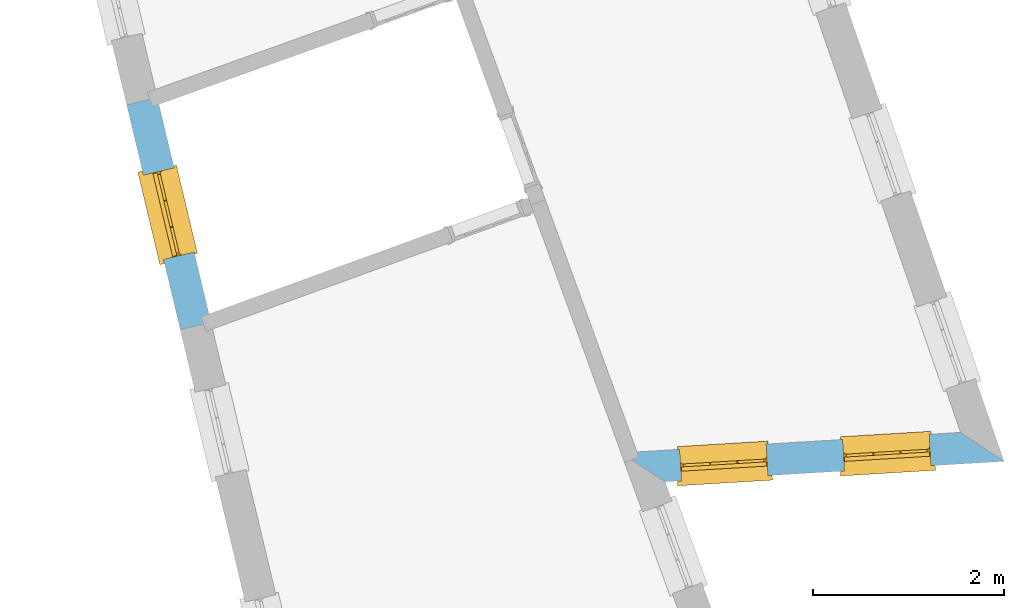
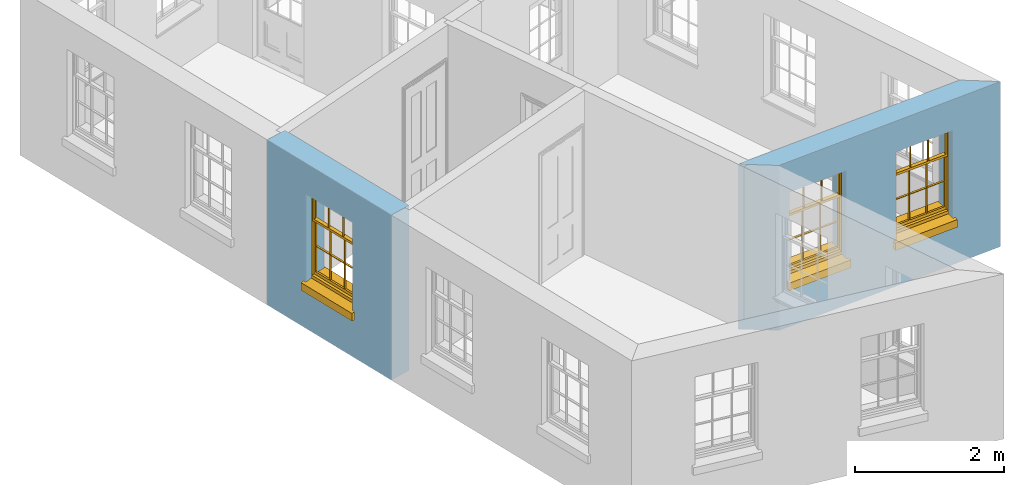
# One storey, part 5 of 12: 3 windows, 3 openings, plus 2 elements that do not belong to this part.
"""IFC2X3 building model written with IfcOpenShell, lengths in metres."""

from ifc_helpers import new_model, si_unit, frame, origin, place, context, subcontext, project, spatial, polyline, outline, extrude, faceted_brep, material, layer, layer_set, layer_usage, element, fill, save


model = new_model("IFC2X3")

# Units and contexts
model_context = context("Model", 3, world=origin())
body_context = subcontext(model_context, "Body", "Model", "MODEL_VIEW")
ifc_project = project(units=[si_unit("PLANEANGLEUNIT", "RADIAN"), si_unit("MASSUNIT", "GRAM", prefix="KILO"), si_unit("FORCEUNIT", "NEWTON", prefix="KILO"), si_unit("LENGTHUNIT", "METRE")], contexts=[model_context])

# Site, building, storey
site_placement = place(None, origin())
site = spatial("IfcSite", under=ifc_project, at=site_placement, CompositionType="ELEMENT")
building_placement = place(None, origin())
building = spatial("IfcBuilding", under=site, at=building_placement, Name="Building plot-12", CompositionType="ELEMENT")
storey_placement = place(None, frame((0.0, 0.0, 6.45)))
storey = spatial("IfcBuildingStorey", under=building, at=storey_placement, Name="Floor 1", CompositionType="ELEMENT", Elevation=6.45)

# Wall, openings, windows
ifc_material = material(Name="Masonry")
ifc_layer = layer(ifc_material, 0.33, ventilated=False)
ifc_layer_set = layer_set([ifc_layer], Name="My Wall")
ifc_layer_usage = layer_usage(ifc_layer_set, "AXIS2", "NEGATIVE", 0.08)
wall_1_placement = place(storey_placement, origin())
wall_1 = element("IfcWallStandardCase", 1, at=wall_1_placement, inside=storey, material=ifc_layer_usage, Name="exterior", context=body_context, shape_type="SweptSolid", body=[
    extrude(outline(polyline([(59.0480704661197, 34.8587662516055), (59.5092760501621, 34.5560013261806), (63.057647216937, 34.7701593682112), (62.6036094343713, 35.0733568984167), (59.0480704661197, 34.8587662516055)])), origin(), (0.0, 0.0, 1.0), 2.7),
])
opening_1_placement = place(storey_placement, frame((0.0, 0.0, 0.75)))
opening_1 = element("IfcOpeningElement", 2, at=opening_1_placement, cuts=wall_1, Name="Opening", ObjectType="Opening", context=body_context, shape_type="SweptSolid", body=[
    extrude(outline(polyline([(59.6792223070511, 34.5662582457403), (60.5875694412412, 34.6210805387303), (60.5676888294976, 34.9504811478322), (59.6593416953075, 34.8956588548422), (59.6792223070511, 34.5662582457403)])), origin(), (0.0, 0.0, 1.0), 1.445),
])
opening_2_placement = place(storey_placement, frame((0.0, 0.0, 0.75)))
opening_2 = element("IfcOpeningElement", 3, at=opening_2_placement, cuts=wall_1, Name="Opening", ObjectType="Opening", context=body_context, shape_type="SweptSolid", body=[
    extrude(outline(polyline([(61.3861163723973, 34.6692759611392), (62.2944635065874, 34.7240982541292), (62.2745828948438, 35.0534988632311), (61.3662357606537, 34.9986765702411), (61.3861163723973, 34.6692759611392)])), origin(), (0.0, 0.0, 1.0), 1.445),
])
window_1_placement = place(storey_placement, frame((59.6641612375484, 34.8158041617266, 0.75), z_axis=(0.0, 0.0, 1.0), x_axis=(0.908347134190073, 0.0548222929900248, 0.0)))
window_1 = element("IfcWindow", 4, at=window_1_placement, inside=storey, Name="bedroom outside window", OverallHeight=1.445, OverallWidth=0.91, context=body_context, shape_type="Brep", held_by="IfcProductRepresentation", body=[
    faceted_brep([(0.876875, -0.105, 0.999097), (0.876875, -0.105, 1.411875), (0.9, -0.105, 1.435), (0.033125, -0.105, 1.411875), (0.033125, -0.105, 0.999097), (0.01, -0.105, 1.435), (0.033125, -0.135, 1.411875), (0.01, -0.135, 1.435), (0.033125, -0.135, 0.999097), (0.876875, -0.135, 1.411875), (0.876875, -0.135, 0.999097), (0.9, -0.135, 1.435), (0.033125, -0.105, 0.960972), (0.01, -0.105, 0.960972), (0.033125, -0.105, 0.548195), (0.876875, -0.105, 0.960972), (0.876875, -0.105, 0.548195), (0.9, -0.105, 0.960972), (0.876875, -0.105, 0.538195), (0.876875, -0.105, 0.125417), (0.9, -0.105, 0.077167), (0.033125, -0.105, 0.125417), (0.033125, -0.105, 0.538195), (0.01, -0.105, 0.077167), (0.9, -0.135, 0.960972), (0.01, -0.135, 0.960972), (-0.0425, -0.25, 0.01), (-0.0425, -0.3, 0.001667), (0.0, -0.25, 0.01), (0.9525, -0.25, 0.01), (0.91, -0.25, 0.01), (0.9525, -0.3, 0.001667), (-0.02, 0.08, 0.077167), (0.0, 0.08, 0.077167), (-0.02, 0.11, 0.077167), (0.0, -0.06, 0.077167), (0.01, -0.06, 0.077167), (0.91, -0.06, 0.077167), (0.91, 0.08, 0.077167), (0.9, -0.06, 0.077167), (0.93, 0.08, 0.077167), (0.93, 0.11, 0.077167), (0.01, -0.105, 0.999097), (0.01, -0.075, 0.999097), (0.9, -0.105, 0.999097), (0.9, -0.075, 0.999097), (0.876875, -0.075, 0.125417), (0.876875, -0.075, 0.538195), (0.9, -0.075, 0.077167), (0.876875, -0.075, 0.548195), (0.876875, -0.075, 0.960972), (0.033125, -0.075, 0.125417), (0.01, -0.075, 0.077167), (0.033125, -0.075, 0.538195), (0.033125, -0.075, 0.960972), (0.033125, -0.075, 0.548195), (-0.02, 0.08, 0.052167), (-0.02, 0.11, 0.052167), (0.93, 0.11, 0.052167), (0.93, 0.08, 0.052167), (0.91, 0.08, 0.052167), (0.0, 0.08, 0.052167), (0.91, -0.15, 0.026667), (0.0, -0.15, 0.026667), (-0.0425, -0.3, -0.123333), (0.9525, -0.3, -0.123333), (-0.0425, -0.25, -0.123333), (0.9525, -0.25, -0.123333), (0.01, -0.06, 1.435), (0.9, -0.06, 1.435), (0.0, -0.06, 1.445), (0.91, -0.06, 1.445), (0.01, -0.15, 0.077167), (0.9, -0.15, 0.077167), (0.592292, -0.105, 0.125417), (0.592292, -0.075, 0.125417), (0.317708, -0.075, 0.125417), (0.317708, -0.105, 0.125417), (0.592292, -0.105, 0.548195), (0.317708, -0.105, 0.548195), (0.317708, -0.105, 0.538195), (0.592292, -0.105, 0.538195), (0.592292, -0.075, 0.548195), (0.317708, -0.075, 0.548195), (0.602292, -0.075, 0.548195), (0.602292, -0.105, 0.548195), (0.317708, -0.075, 0.538195), (0.307708, -0.075, 0.125417), (0.307708, -0.075, 0.538195), (0.602292, -0.075, 0.538195), (0.602292, -0.075, 0.125417), (0.592292, -0.075, 0.538195), (0.307708, -0.075, 0.548195), (0.317708, -0.075, 0.960972), (0.307708, -0.075, 0.960972), (0.602292, -0.075, 0.960972), (0.592292, -0.075, 0.960972), (0.307708, -0.105, 0.538195), (0.307708, -0.105, 0.125417), (0.307708, -0.105, 0.548195), (0.307708, -0.105, 0.960972), (0.592292, -0.105, 0.960972), (0.317708, -0.105, 0.960972), (0.602292, -0.105, 0.960972), (0.602292, -0.105, 0.538195), (0.602292, -0.105, 0.125417), (0.317708, -0.135, 1.411875), (0.307708, -0.135, 1.411875), (0.307708, -0.135, 0.999097), (0.317708, -0.135, 0.999097), (0.602292, -0.135, 1.411875), (0.592292, -0.135, 1.411875), (0.592292, -0.135, 0.999097), (0.602292, -0.135, 0.999097), (0.317708, -0.105, 0.999097), (0.307708, -0.105, 0.999097), (0.307708, -0.105, 1.411875), (0.317708, -0.105, 1.411875), (0.602292, -0.105, 0.999097), (0.592292, -0.105, 0.999097), (0.592292, -0.105, 1.411875), (0.602292, -0.105, 1.411875), (0.91, -0.15, 1.445), (0.9, -0.15, 1.435), (0.01, -0.15, 1.435), (0.0, -0.15, 1.445), (0.91, -0.25, 0.0), (0.0, -0.25, 0.0), (0.91, 0.08, 0.0), (0.0, 0.08, 0.0)], [[[0, 1, 2]], [[3, 4, 5]], [[6, 7, 8]], [[9, 10, 11]], [[12, 13, 14]], [[15, 16, 17]], [[18, 19, 20]], [[21, 22, 23]], [[24, 15, 17]], [[13, 12, 25]], [[26, 27, 28]], [[29, 30, 31]], [[32, 33, 34]], [[35, 36, 33]], [[37, 38, 39]], [[40, 41, 38]], [[42, 4, 43]], [[44, 45, 0]], [[46, 47, 48]], [[49, 50, 45]], [[51, 52, 53]], [[54, 55, 43]], [[38, 33, 36, 39]], [[41, 34, 33, 38]], [[56, 32, 34, 57]], [[57, 34, 41, 58]], [[58, 41, 40, 59]], [[57, 58, 60, 61]], [[52, 48, 39, 36]], [[62, 63, 28, 30]], [[27, 31, 30, 28]], [[27, 64, 65, 31]], [[66, 67, 65, 64]], [[2, 5, 68, 69]], [[68, 70, 71, 69]], [[20, 23, 72, 73]], [[73, 72, 63, 62]], [[74, 75, 76, 77]], [[78, 79, 80, 81]], [[78, 82, 83, 79]], [[16, 49, 84, 85]], [[86, 76, 87, 88]], [[89, 90, 75, 91]], [[92, 88, 53, 55]], [[82, 91, 86, 83]], [[93, 83, 92, 94]], [[95, 84, 82, 96]], [[89, 84, 49, 47]], [[97, 88, 87, 98]], [[22, 53, 88, 97]], [[81, 91, 75, 74]], [[80, 86, 91, 81]], [[77, 76, 86, 80]], [[99, 92, 55, 14]], [[100, 94, 92, 99]], [[101, 96, 82, 78]], [[79, 83, 93, 102]], [[85, 84, 95, 103]], [[104, 89, 47, 18]], [[105, 90, 89, 104]], [[104, 18, 16, 85]], [[80, 97, 98, 77]], [[104, 81, 74, 105]], [[103, 101, 78, 85]], [[99, 14, 22, 97]], [[102, 100, 99, 79]], [[106, 107, 108, 109]], [[110, 111, 112, 113]], [[114, 115, 116, 117]], [[118, 119, 120, 121]], [[107, 116, 115, 108]], [[111, 120, 119, 112]], [[109, 114, 117, 106]], [[113, 118, 121, 110]], [[85, 78, 81, 104]], [[84, 89, 91, 82]], [[83, 86, 88, 92]], [[79, 99, 97, 80]], [[109, 112, 119, 114]], [[102, 93, 96, 101]], [[106, 117, 120, 111]], [[98, 87, 51, 21]], [[6, 3, 116, 107]], [[110, 121, 1, 9]], [[19, 46, 90, 105]], [[26, 66, 64, 27]], [[29, 31, 65, 67]], [[25, 24, 112, 109]], [[11, 7, 106, 111]], [[75, 48, 52, 76]], [[43, 45, 96, 93]], [[45, 43, 114, 119]], [[5, 2, 120, 117]], [[24, 25, 102, 101]], [[42, 5, 4]], [[2, 44, 0]], [[49, 45, 48, 47]], [[52, 43, 55, 53]], [[14, 13, 23, 22]], [[20, 17, 16, 18]], [[24, 11, 10]], [[25, 8, 7]], [[8, 4, 3, 6]], [[9, 1, 0, 10]], [[15, 50, 49, 16]], [[18, 47, 46, 19]], [[21, 51, 53, 22]], [[14, 55, 54, 12]], [[44, 2, 69, 45]], [[68, 5, 42, 43]], [[36, 35, 70, 68]], [[39, 69, 71, 37]], [[62, 122, 123, 73]], [[63, 72, 124, 125]], [[8, 108, 115, 4]], [[113, 10, 0, 118]], [[94, 100, 12, 54]], [[17, 20, 73, 24]], [[72, 23, 13, 25]], [[52, 36, 68, 43]], [[69, 39, 48, 45]], [[11, 24, 73, 123]], [[7, 124, 72, 25]], [[23, 77, 98]], [[98, 21, 23]], [[105, 74, 20]], [[20, 19, 105]], [[20, 74, 77, 23]], [[113, 112, 24]], [[24, 10, 113]], [[25, 109, 108]], [[108, 8, 25]], [[110, 9, 11]], [[11, 111, 110]], [[7, 6, 107]], [[107, 106, 7]], [[5, 117, 116]], [[116, 3, 5]], [[121, 120, 2]], [[2, 1, 121]], [[11, 123, 124, 7]], [[122, 125, 124, 123]], [[43, 93, 94]], [[94, 54, 43]], [[96, 45, 95]], [[50, 95, 45]], [[15, 103, 95, 50]], [[48, 75, 90]], [[90, 46, 48]], [[87, 76, 52]], [[52, 51, 87]], [[103, 15, 24]], [[24, 101, 103]], [[100, 102, 25]], [[25, 12, 100]], [[115, 114, 43]], [[43, 4, 115]], [[118, 0, 45]], [[45, 119, 118]], [[71, 70, 125, 122]], [[70, 35, 63, 125]], [[122, 62, 37, 71]], [[126, 67, 66, 127]], [[60, 58, 59]], [[38, 60, 59, 40]], [[61, 56, 57]], [[32, 56, 61, 33]], [[61, 60, 128, 129]], [[62, 60, 38, 37]], [[126, 128, 60, 62]], [[33, 61, 63, 35]], [[61, 129, 127, 63]], [[128, 126, 127, 129]], [[28, 127, 66, 26]], [[63, 127, 28]], [[29, 67, 126, 30]], [[30, 126, 62]]]),
])
fill(opening_1, window_1)
window_2_placement = place(storey_placement, frame((61.3710553028946, 34.9188218771254, 0.75), z_axis=(0.0, 0.0, 1.0), x_axis=(0.908347134190073, 0.0548222929900248, 0.0)))
window_2 = element("IfcWindow", 5, at=window_2_placement, inside=storey, Name="bedroom outside window", OverallHeight=1.445, OverallWidth=0.91, context=body_context, shape_type="Brep", held_by="IfcProductRepresentation", body=[
    faceted_brep([(0.876875, -0.105, 0.999097), (0.876875, -0.105, 1.411875), (0.9, -0.105, 1.435), (0.033125, -0.105, 1.411875), (0.033125, -0.105, 0.999097), (0.01, -0.105, 1.435), (0.033125, -0.135, 1.411875), (0.01, -0.135, 1.435), (0.033125, -0.135, 0.999097), (0.876875, -0.135, 1.411875), (0.876875, -0.135, 0.999097), (0.9, -0.135, 1.435), (0.033125, -0.105, 0.960972), (0.01, -0.105, 0.960972), (0.033125, -0.105, 0.548195), (0.876875, -0.105, 0.960972), (0.876875, -0.105, 0.548195), (0.9, -0.105, 0.960972), (0.876875, -0.105, 0.538195), (0.876875, -0.105, 0.125417), (0.9, -0.105, 0.077167), (0.033125, -0.105, 0.125417), (0.033125, -0.105, 0.538195), (0.01, -0.105, 0.077167), (0.9, -0.135, 0.960972), (0.01, -0.135, 0.960972), (-0.0425, -0.25, 0.01), (-0.0425, -0.3, 0.001667), (0.0, -0.25, 0.01), (0.9525, -0.25, 0.01), (0.91, -0.25, 0.01), (0.9525, -0.3, 0.001667), (-0.02, 0.08, 0.077167), (0.0, 0.08, 0.077167), (-0.02, 0.11, 0.077167), (0.0, -0.06, 0.077167), (0.01, -0.06, 0.077167), (0.91, -0.06, 0.077167), (0.91, 0.08, 0.077167), (0.9, -0.06, 0.077167), (0.93, 0.08, 0.077167), (0.93, 0.11, 0.077167), (0.01, -0.105, 0.999097), (0.01, -0.075, 0.999097), (0.9, -0.105, 0.999097), (0.9, -0.075, 0.999097), (0.876875, -0.075, 0.125417), (0.876875, -0.075, 0.538195), (0.9, -0.075, 0.077167), (0.876875, -0.075, 0.548195), (0.876875, -0.075, 0.960972), (0.033125, -0.075, 0.125417), (0.01, -0.075, 0.077167), (0.033125, -0.075, 0.538195), (0.033125, -0.075, 0.960972), (0.033125, -0.075, 0.548195), (-0.02, 0.08, 0.052167), (-0.02, 0.11, 0.052167), (0.93, 0.11, 0.052167), (0.93, 0.08, 0.052167), (0.91, 0.08, 0.052167), (0.0, 0.08, 0.052167), (0.91, -0.15, 0.026667), (0.0, -0.15, 0.026667), (-0.0425, -0.3, -0.123333), (0.9525, -0.3, -0.123333), (-0.0425, -0.25, -0.123333), (0.9525, -0.25, -0.123333), (0.01, -0.06, 1.435), (0.9, -0.06, 1.435), (0.0, -0.06, 1.445), (0.91, -0.06, 1.445), (0.01, -0.15, 0.077167), (0.9, -0.15, 0.077167), (0.592292, -0.105, 0.125417), (0.592292, -0.075, 0.125417), (0.317708, -0.075, 0.125417), (0.317708, -0.105, 0.125417), (0.592292, -0.105, 0.548195), (0.317708, -0.105, 0.548195), (0.317708, -0.105, 0.538195), (0.592292, -0.105, 0.538195), (0.592292, -0.075, 0.548195), (0.317708, -0.075, 0.548195), (0.602292, -0.075, 0.548195), (0.602292, -0.105, 0.548195), (0.317708, -0.075, 0.538195), (0.307708, -0.075, 0.125417), (0.307708, -0.075, 0.538195), (0.602292, -0.075, 0.538195), (0.602292, -0.075, 0.125417), (0.592292, -0.075, 0.538195), (0.307708, -0.075, 0.548195), (0.317708, -0.075, 0.960972), (0.307708, -0.075, 0.960972), (0.602292, -0.075, 0.960972), (0.592292, -0.075, 0.960972), (0.307708, -0.105, 0.538195), (0.307708, -0.105, 0.125417), (0.307708, -0.105, 0.548195), (0.307708, -0.105, 0.960972), (0.592292, -0.105, 0.960972), (0.317708, -0.105, 0.960972), (0.602292, -0.105, 0.960972), (0.602292, -0.105, 0.538195), (0.602292, -0.105, 0.125417), (0.317708, -0.135, 1.411875), (0.307708, -0.135, 1.411875), (0.307708, -0.135, 0.999097), (0.317708, -0.135, 0.999097), (0.602292, -0.135, 1.411875), (0.592292, -0.135, 1.411875), (0.592292, -0.135, 0.999097), (0.602292, -0.135, 0.999097), (0.317708, -0.105, 0.999097), (0.307708, -0.105, 0.999097), (0.307708, -0.105, 1.411875), (0.317708, -0.105, 1.411875), (0.602292, -0.105, 0.999097), (0.592292, -0.105, 0.999097), (0.592292, -0.105, 1.411875), (0.602292, -0.105, 1.411875), (0.91, -0.15, 1.445), (0.9, -0.15, 1.435), (0.01, -0.15, 1.435), (0.0, -0.15, 1.445), (0.91, -0.25, 0.0), (0.0, -0.25, 0.0), (0.91, 0.08, 0.0), (0.0, 0.08, 0.0)], [[[0, 1, 2]], [[3, 4, 5]], [[6, 7, 8]], [[9, 10, 11]], [[12, 13, 14]], [[15, 16, 17]], [[18, 19, 20]], [[21, 22, 23]], [[24, 15, 17]], [[13, 12, 25]], [[26, 27, 28]], [[29, 30, 31]], [[32, 33, 34]], [[35, 36, 33]], [[37, 38, 39]], [[40, 41, 38]], [[42, 4, 43]], [[44, 45, 0]], [[46, 47, 48]], [[49, 50, 45]], [[51, 52, 53]], [[54, 55, 43]], [[38, 33, 36, 39]], [[41, 34, 33, 38]], [[56, 32, 34, 57]], [[57, 34, 41, 58]], [[58, 41, 40, 59]], [[57, 58, 60, 61]], [[52, 48, 39, 36]], [[62, 63, 28, 30]], [[27, 31, 30, 28]], [[27, 64, 65, 31]], [[66, 67, 65, 64]], [[2, 5, 68, 69]], [[68, 70, 71, 69]], [[20, 23, 72, 73]], [[73, 72, 63, 62]], [[74, 75, 76, 77]], [[78, 79, 80, 81]], [[78, 82, 83, 79]], [[16, 49, 84, 85]], [[86, 76, 87, 88]], [[89, 90, 75, 91]], [[92, 88, 53, 55]], [[82, 91, 86, 83]], [[93, 83, 92, 94]], [[95, 84, 82, 96]], [[89, 84, 49, 47]], [[97, 88, 87, 98]], [[22, 53, 88, 97]], [[81, 91, 75, 74]], [[80, 86, 91, 81]], [[77, 76, 86, 80]], [[99, 92, 55, 14]], [[100, 94, 92, 99]], [[101, 96, 82, 78]], [[79, 83, 93, 102]], [[85, 84, 95, 103]], [[104, 89, 47, 18]], [[105, 90, 89, 104]], [[104, 18, 16, 85]], [[80, 97, 98, 77]], [[104, 81, 74, 105]], [[103, 101, 78, 85]], [[99, 14, 22, 97]], [[102, 100, 99, 79]], [[106, 107, 108, 109]], [[110, 111, 112, 113]], [[114, 115, 116, 117]], [[118, 119, 120, 121]], [[107, 116, 115, 108]], [[111, 120, 119, 112]], [[109, 114, 117, 106]], [[113, 118, 121, 110]], [[85, 78, 81, 104]], [[84, 89, 91, 82]], [[83, 86, 88, 92]], [[79, 99, 97, 80]], [[109, 112, 119, 114]], [[102, 93, 96, 101]], [[106, 117, 120, 111]], [[98, 87, 51, 21]], [[6, 3, 116, 107]], [[110, 121, 1, 9]], [[19, 46, 90, 105]], [[26, 66, 64, 27]], [[29, 31, 65, 67]], [[25, 24, 112, 109]], [[11, 7, 106, 111]], [[75, 48, 52, 76]], [[43, 45, 96, 93]], [[45, 43, 114, 119]], [[5, 2, 120, 117]], [[24, 25, 102, 101]], [[42, 5, 4]], [[2, 44, 0]], [[49, 45, 48, 47]], [[52, 43, 55, 53]], [[14, 13, 23, 22]], [[20, 17, 16, 18]], [[24, 11, 10]], [[25, 8, 7]], [[8, 4, 3, 6]], [[9, 1, 0, 10]], [[15, 50, 49, 16]], [[18, 47, 46, 19]], [[21, 51, 53, 22]], [[14, 55, 54, 12]], [[44, 2, 69, 45]], [[68, 5, 42, 43]], [[36, 35, 70, 68]], [[39, 69, 71, 37]], [[62, 122, 123, 73]], [[63, 72, 124, 125]], [[8, 108, 115, 4]], [[113, 10, 0, 118]], [[94, 100, 12, 54]], [[17, 20, 73, 24]], [[72, 23, 13, 25]], [[52, 36, 68, 43]], [[69, 39, 48, 45]], [[11, 24, 73, 123]], [[7, 124, 72, 25]], [[23, 77, 98]], [[98, 21, 23]], [[105, 74, 20]], [[20, 19, 105]], [[20, 74, 77, 23]], [[113, 112, 24]], [[24, 10, 113]], [[25, 109, 108]], [[108, 8, 25]], [[110, 9, 11]], [[11, 111, 110]], [[7, 6, 107]], [[107, 106, 7]], [[5, 117, 116]], [[116, 3, 5]], [[121, 120, 2]], [[2, 1, 121]], [[11, 123, 124, 7]], [[122, 125, 124, 123]], [[43, 93, 94]], [[94, 54, 43]], [[96, 45, 95]], [[50, 95, 45]], [[15, 103, 95, 50]], [[48, 75, 90]], [[90, 46, 48]], [[87, 76, 52]], [[52, 51, 87]], [[103, 15, 24]], [[24, 101, 103]], [[100, 102, 25]], [[25, 12, 100]], [[115, 114, 43]], [[43, 4, 115]], [[118, 0, 45]], [[45, 119, 118]], [[71, 70, 125, 122]], [[70, 35, 63, 125]], [[122, 62, 37, 71]], [[126, 67, 66, 127]], [[60, 58, 59]], [[38, 60, 59, 40]], [[61, 56, 57]], [[32, 56, 61, 33]], [[61, 60, 128, 129]], [[62, 60, 38, 37]], [[126, 128, 60, 62]], [[33, 61, 63, 35]], [[61, 129, 127, 63]], [[128, 126, 127, 129]], [[28, 127, 66, 26]], [[63, 127, 28]], [[29, 67, 126, 30]], [[30, 126, 62]]]),
])
fill(opening_2, window_2)

# Wall, opening, window
wall_2_placement = place(storey_placement, origin())
wall_2 = element("IfcWallStandardCase", 6, at=wall_2_placement, inside=storey, material=ifc_layer_usage, Name="exterior", context=body_context, shape_type="SweptSolid", body=[
    extrude(outline(polyline([(54.1926114220858, 38.578496779823), (53.8716114947725, 38.5019523700673), (54.4326600181389, 36.1491151636064), (54.7536599454522, 36.2256595733621), (54.1926114220858, 38.578496779823)])), origin(), (0.0, 0.0, 1.0), 2.7),
])
opening_3_placement = place(storey_placement, frame((0.0, 0.0, 0.75)))
opening_3 = element("IfcOpeningElement", 7, at=opening_3_placement, cuts=wall_2, Name="Opening", ObjectType="Opening", context=body_context, shape_type="SweptSolid", body=[
    extrude(outline(polyline([(54.0465972520955, 37.7681245757082), (54.2576742608158, 36.8829429579655), (54.5786741881291, 36.9594873677212), (54.3675971794088, 37.844668985464), (54.0465972520955, 37.7681245757082)])), origin(), (0.0, 0.0, 1.0), 1.445),
])
window_3_placement = place(storey_placement, frame((54.2897790152116, 37.8261127649171, 0.75), z_axis=(0.0, 0.0, 1.0), x_axis=(0.211077008720331, -0.885181617742752, 0.0)))
window_3 = element("IfcWindow", 8, at=window_3_placement, inside=storey, Name="circulation outside window", OverallHeight=1.445, OverallWidth=0.91, context=body_context, shape_type="Brep", held_by="IfcProductRepresentation", body=[
    faceted_brep([(0.876875, -0.105, 0.999097), (0.876875, -0.105, 1.411875), (0.9, -0.105, 1.435), (0.033125, -0.105, 1.411875), (0.033125, -0.105, 0.999097), (0.01, -0.105, 1.435), (0.033125, -0.135, 1.411875), (0.01, -0.135, 1.435), (0.033125, -0.135, 0.999097), (0.876875, -0.135, 1.411875), (0.876875, -0.135, 0.999097), (0.9, -0.135, 1.435), (0.033125, -0.105, 0.960972), (0.01, -0.105, 0.960972), (0.033125, -0.105, 0.548195), (0.876875, -0.105, 0.960972), (0.876875, -0.105, 0.548195), (0.9, -0.105, 0.960972), (0.876875, -0.105, 0.538195), (0.876875, -0.105, 0.125417), (0.9, -0.105, 0.077167), (0.033125, -0.105, 0.125417), (0.033125, -0.105, 0.538195), (0.01, -0.105, 0.077167), (0.9, -0.135, 0.960972), (0.01, -0.135, 0.960972), (-0.0425, -0.25, 0.01), (-0.0425, -0.3, 0.001667), (0.0, -0.25, 0.01), (0.9525, -0.25, 0.01), (0.91, -0.25, 0.01), (0.9525, -0.3, 0.001667), (-0.02, 0.08, 0.077167), (0.0, 0.08, 0.077167), (-0.02, 0.11, 0.077167), (0.0, -0.06, 0.077167), (0.01, -0.06, 0.077167), (0.91, -0.06, 0.077167), (0.91, 0.08, 0.077167), (0.9, -0.06, 0.077167), (0.93, 0.08, 0.077167), (0.93, 0.11, 0.077167), (0.01, -0.105, 0.999097), (0.01, -0.075, 0.999097), (0.9, -0.105, 0.999097), (0.9, -0.075, 0.999097), (0.876875, -0.075, 0.125417), (0.876875, -0.075, 0.538195), (0.9, -0.075, 0.077167), (0.876875, -0.075, 0.548195), (0.876875, -0.075, 0.960972), (0.033125, -0.075, 0.125417), (0.01, -0.075, 0.077167), (0.033125, -0.075, 0.538195), (0.033125, -0.075, 0.960972), (0.033125, -0.075, 0.548195), (-0.02, 0.08, 0.052167), (-0.02, 0.11, 0.052167), (0.93, 0.11, 0.052167), (0.93, 0.08, 0.052167), (0.91, 0.08, 0.052167), (0.0, 0.08, 0.052167), (0.91, -0.15, 0.026667), (0.0, -0.15, 0.026667), (-0.0425, -0.3, -0.123333), (0.9525, -0.3, -0.123333), (-0.0425, -0.25, -0.123333), (0.9525, -0.25, -0.123333), (0.01, -0.06, 1.435), (0.9, -0.06, 1.435), (0.0, -0.06, 1.445), (0.91, -0.06, 1.445), (0.01, -0.15, 0.077167), (0.9, -0.15, 0.077167), (0.592292, -0.105, 0.125417), (0.592292, -0.075, 0.125417), (0.317708, -0.075, 0.125417), (0.317708, -0.105, 0.125417), (0.592292, -0.105, 0.548195), (0.317708, -0.105, 0.548195), (0.317708, -0.105, 0.538195), (0.592292, -0.105, 0.538195), (0.592292, -0.075, 0.548195), (0.317708, -0.075, 0.548195), (0.602292, -0.075, 0.548195), (0.602292, -0.105, 0.548195), (0.317708, -0.075, 0.538195), (0.307708, -0.075, 0.125417), (0.307708, -0.075, 0.538195), (0.602292, -0.075, 0.538195), (0.602292, -0.075, 0.125417), (0.592292, -0.075, 0.538195), (0.307708, -0.075, 0.548195), (0.317708, -0.075, 0.960972), (0.307708, -0.075, 0.960972), (0.602292, -0.075, 0.960972), (0.592292, -0.075, 0.960972), (0.307708, -0.105, 0.538195), (0.307708, -0.105, 0.125417), (0.307708, -0.105, 0.548195), (0.307708, -0.105, 0.960972), (0.592292, -0.105, 0.960972), (0.317708, -0.105, 0.960972), (0.602292, -0.105, 0.960972), (0.602292, -0.105, 0.538195), (0.602292, -0.105, 0.125417), (0.317708, -0.135, 1.411875), (0.307708, -0.135, 1.411875), (0.307708, -0.135, 0.999097), (0.317708, -0.135, 0.999097), (0.602292, -0.135, 1.411875), (0.592292, -0.135, 1.411875), (0.592292, -0.135, 0.999097), (0.602292, -0.135, 0.999097), (0.317708, -0.105, 0.999097), (0.307708, -0.105, 0.999097), (0.307708, -0.105, 1.411875), (0.317708, -0.105, 1.411875), (0.602292, -0.105, 0.999097), (0.592292, -0.105, 0.999097), (0.592292, -0.105, 1.411875), (0.602292, -0.105, 1.411875), (0.91, -0.15, 1.445), (0.9, -0.15, 1.435), (0.01, -0.15, 1.435), (0.0, -0.15, 1.445), (0.91, -0.25, 0.0), (0.0, -0.25, 0.0), (0.91, 0.08, 0.0), (0.0, 0.08, 0.0)], [[[0, 1, 2]], [[3, 4, 5]], [[6, 7, 8]], [[9, 10, 11]], [[12, 13, 14]], [[15, 16, 17]], [[18, 19, 20]], [[21, 22, 23]], [[24, 15, 17]], [[13, 12, 25]], [[26, 27, 28]], [[29, 30, 31]], [[32, 33, 34]], [[35, 36, 33]], [[37, 38, 39]], [[40, 41, 38]], [[42, 4, 43]], [[44, 45, 0]], [[46, 47, 48]], [[49, 50, 45]], [[51, 52, 53]], [[54, 55, 43]], [[38, 33, 36, 39]], [[41, 34, 33, 38]], [[56, 32, 34, 57]], [[57, 34, 41, 58]], [[58, 41, 40, 59]], [[57, 58, 60, 61]], [[52, 48, 39, 36]], [[62, 63, 28, 30]], [[27, 31, 30, 28]], [[27, 64, 65, 31]], [[66, 67, 65, 64]], [[2, 5, 68, 69]], [[68, 70, 71, 69]], [[20, 23, 72, 73]], [[73, 72, 63, 62]], [[74, 75, 76, 77]], [[78, 79, 80, 81]], [[78, 82, 83, 79]], [[16, 49, 84, 85]], [[86, 76, 87, 88]], [[89, 90, 75, 91]], [[92, 88, 53, 55]], [[82, 91, 86, 83]], [[93, 83, 92, 94]], [[95, 84, 82, 96]], [[89, 84, 49, 47]], [[97, 88, 87, 98]], [[22, 53, 88, 97]], [[81, 91, 75, 74]], [[80, 86, 91, 81]], [[77, 76, 86, 80]], [[99, 92, 55, 14]], [[100, 94, 92, 99]], [[101, 96, 82, 78]], [[79, 83, 93, 102]], [[85, 84, 95, 103]], [[104, 89, 47, 18]], [[105, 90, 89, 104]], [[104, 18, 16, 85]], [[80, 97, 98, 77]], [[104, 81, 74, 105]], [[103, 101, 78, 85]], [[99, 14, 22, 97]], [[102, 100, 99, 79]], [[106, 107, 108, 109]], [[110, 111, 112, 113]], [[114, 115, 116, 117]], [[118, 119, 120, 121]], [[107, 116, 115, 108]], [[111, 120, 119, 112]], [[109, 114, 117, 106]], [[113, 118, 121, 110]], [[85, 78, 81, 104]], [[84, 89, 91, 82]], [[83, 86, 88, 92]], [[79, 99, 97, 80]], [[109, 112, 119, 114]], [[102, 93, 96, 101]], [[106, 117, 120, 111]], [[98, 87, 51, 21]], [[6, 3, 116, 107]], [[110, 121, 1, 9]], [[19, 46, 90, 105]], [[26, 66, 64, 27]], [[29, 31, 65, 67]], [[25, 24, 112, 109]], [[11, 7, 106, 111]], [[75, 48, 52, 76]], [[43, 45, 96, 93]], [[45, 43, 114, 119]], [[5, 2, 120, 117]], [[24, 25, 102, 101]], [[42, 5, 4]], [[2, 44, 0]], [[49, 45, 48, 47]], [[52, 43, 55, 53]], [[14, 13, 23, 22]], [[20, 17, 16, 18]], [[24, 11, 10]], [[25, 8, 7]], [[8, 4, 3, 6]], [[9, 1, 0, 10]], [[15, 50, 49, 16]], [[18, 47, 46, 19]], [[21, 51, 53, 22]], [[14, 55, 54, 12]], [[44, 2, 69, 45]], [[68, 5, 42, 43]], [[36, 35, 70, 68]], [[39, 69, 71, 37]], [[62, 122, 123, 73]], [[63, 72, 124, 125]], [[8, 108, 115, 4]], [[113, 10, 0, 118]], [[94, 100, 12, 54]], [[17, 20, 73, 24]], [[72, 23, 13, 25]], [[52, 36, 68, 43]], [[69, 39, 48, 45]], [[11, 24, 73, 123]], [[7, 124, 72, 25]], [[23, 77, 98]], [[98, 21, 23]], [[105, 74, 20]], [[20, 19, 105]], [[20, 74, 77, 23]], [[113, 112, 24]], [[24, 10, 113]], [[25, 109, 108]], [[108, 8, 25]], [[110, 9, 11]], [[11, 111, 110]], [[7, 6, 107]], [[107, 106, 7]], [[5, 117, 116]], [[116, 3, 5]], [[121, 120, 2]], [[2, 1, 121]], [[11, 123, 124, 7]], [[122, 125, 124, 123]], [[43, 93, 94]], [[94, 54, 43]], [[96, 45, 95]], [[50, 95, 45]], [[15, 103, 95, 50]], [[48, 75, 90]], [[90, 46, 48]], [[87, 76, 52]], [[52, 51, 87]], [[103, 15, 24]], [[24, 101, 103]], [[100, 102, 25]], [[25, 12, 100]], [[115, 114, 43]], [[43, 4, 115]], [[118, 0, 45]], [[45, 119, 118]], [[71, 70, 125, 122]], [[70, 35, 63, 125]], [[122, 62, 37, 71]], [[126, 67, 66, 127]], [[60, 58, 59]], [[38, 60, 59, 40]], [[61, 56, 57]], [[32, 56, 61, 33]], [[61, 60, 128, 129]], [[62, 60, 38, 37]], [[126, 128, 60, 62]], [[33, 61, 63, 35]], [[61, 129, 127, 63]], [[128, 126, 127, 129]], [[28, 127, 66, 26]], [[63, 127, 28]], [[29, 67, 126, 30]], [[30, 126, 62]]]),
])
fill(opening_3, window_3)

save(model, "model.ifc")
